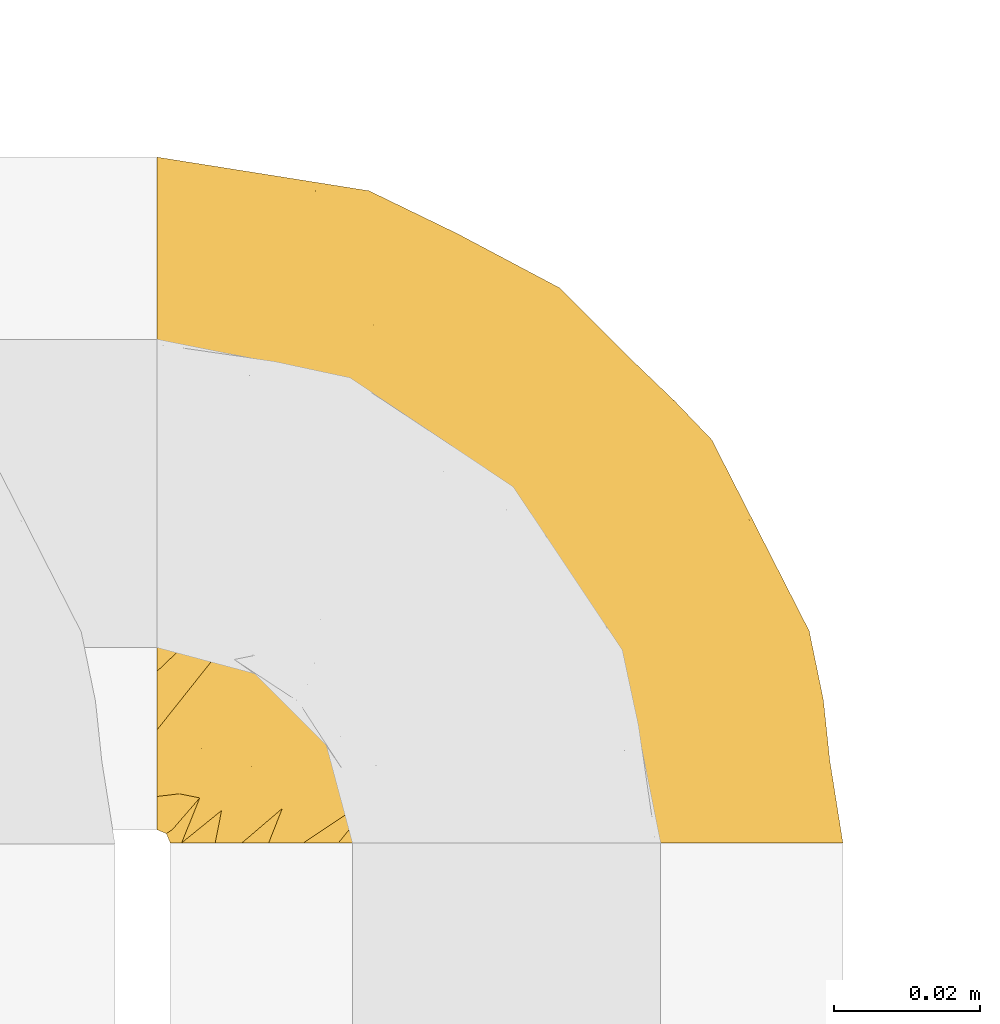
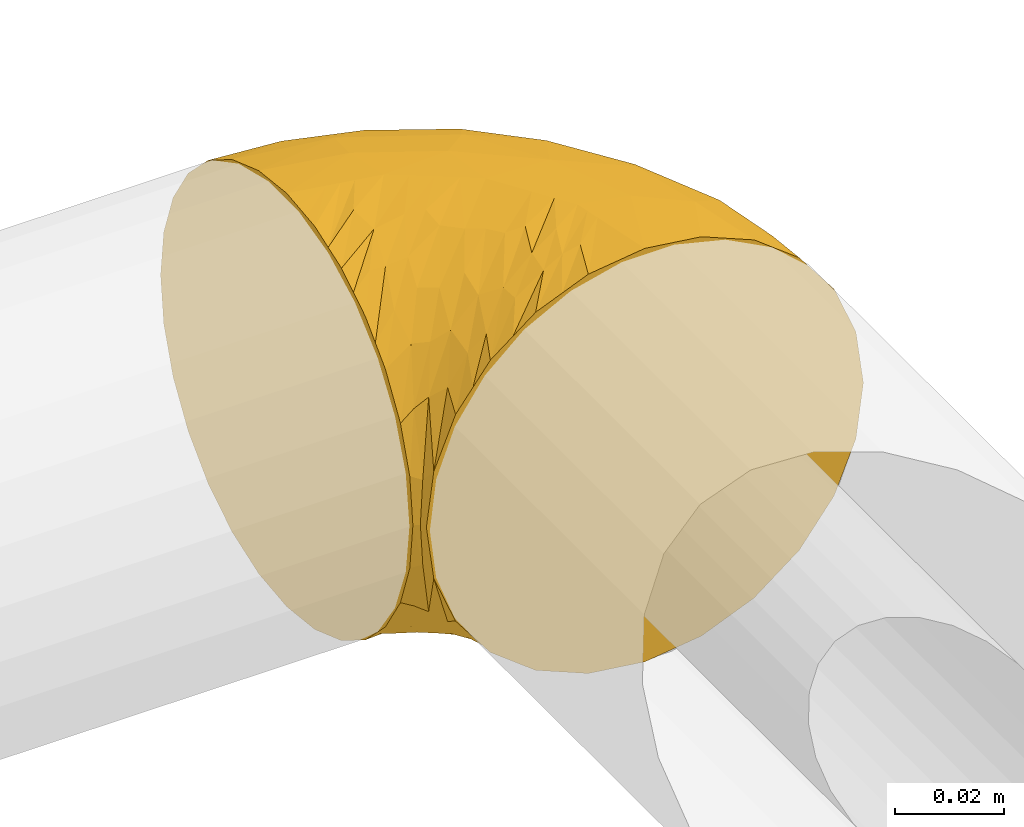
# One storey, part 514 of 827: 1 covering.
"""IFC2X3 building model written with IfcOpenShell, lengths in millimetres."""

from ifc_helpers import new_model, entity, si_unit, converted_unit, derived_unit, direction, frame, origin, place, context, subcontext, project, spatial, faceted_brep, element, save


model = new_model("IFC2X3")

# Units and contexts
model_context = context("Model", 3, precision=0.01, world=origin(), true_north=direction((6.12303176911189e-17, 1.0)))
body_context = subcontext(model_context, "Body", "Model", "MODEL_VIEW")
ifc_project = project(units=[si_unit("LENGTHUNIT", "METRE", prefix="MILLI"), si_unit("AREAUNIT", "SQUARE_METRE"), si_unit("VOLUMEUNIT", "CUBIC_METRE"), converted_unit("PLANEANGLEUNIT", "DEGREE", entity("IfcRatioMeasure", 0.0174532925199433), si_unit("PLANEANGLEUNIT", "RADIAN"), dimensions=[0, 0, 0, 0, 0, 0, 0]), si_unit("MASSUNIT", "GRAM", prefix="KILO"), derived_unit("MASSDENSITYUNIT", [(si_unit("MASSUNIT", "GRAM", prefix="KILO"), 1), (si_unit("LENGTHUNIT", "METRE"), -3)]), derived_unit("MOMENTOFINERTIAUNIT", [(si_unit("LENGTHUNIT", "METRE"), 4)]), si_unit("TIMEUNIT", "SECOND"), si_unit("FREQUENCYUNIT", "HERTZ"), si_unit("THERMODYNAMICTEMPERATUREUNIT", "DEGREE_CELSIUS"), derived_unit("THERMALTRANSMITTANCEUNIT", [(si_unit("MASSUNIT", "GRAM", prefix="KILO"), 1), (si_unit("THERMODYNAMICTEMPERATUREUNIT", "KELVIN"), -1), (si_unit("TIMEUNIT", "SECOND"), -3)]), derived_unit("VOLUMETRICFLOWRATEUNIT", [(si_unit("LENGTHUNIT", "METRE"), 3), (si_unit("TIMEUNIT", "SECOND"), -1)]), derived_unit("MASSFLOWRATEUNIT", [(si_unit("MASSUNIT", "GRAM", prefix="KILO"), 1), (si_unit("TIMEUNIT", "SECOND"), -1)]), derived_unit("ROTATIONALFREQUENCYUNIT", [(si_unit("TIMEUNIT", "SECOND"), -1)]), si_unit("ELECTRICCURRENTUNIT", "AMPERE"), si_unit("ELECTRICVOLTAGEUNIT", "VOLT"), si_unit("POWERUNIT", "WATT"), si_unit("FORCEUNIT", "NEWTON", prefix="KILO"), si_unit("ILLUMINANCEUNIT", "LUX"), si_unit("LUMINOUSFLUXUNIT", "LUMEN"), si_unit("LUMINOUSINTENSITYUNIT", "CANDELA"), derived_unit("USERDEFINED", [(si_unit("MASSUNIT", "GRAM", prefix="KILO"), -1), (si_unit("LENGTHUNIT", "METRE"), -2), (si_unit("TIMEUNIT", "SECOND"), 3), (si_unit("LUMINOUSFLUXUNIT", "LUMEN"), 1)]), derived_unit("LINEARVELOCITYUNIT", [(si_unit("LENGTHUNIT", "METRE"), 1), (si_unit("TIMEUNIT", "SECOND"), -1)]), si_unit("PRESSUREUNIT", "PASCAL"), derived_unit("USERDEFINED", [(si_unit("LENGTHUNIT", "METRE"), -2), (si_unit("MASSUNIT", "GRAM", prefix="KILO"), 1), (si_unit("TIMEUNIT", "SECOND"), -2)]), derived_unit("LINEARFORCEUNIT", [(si_unit("MASSUNIT", "GRAM", prefix="KILO"), 1), (si_unit("LENGTHUNIT", "METRE"), 1), (si_unit("TIMEUNIT", "SECOND"), -2), (si_unit("LENGTHUNIT", "METRE"), -1)]), derived_unit("PLANARFORCEUNIT", [(si_unit("MASSUNIT", "GRAM", prefix="KILO"), 1), (si_unit("LENGTHUNIT", "METRE"), 1), (si_unit("TIMEUNIT", "SECOND"), -2), (si_unit("LENGTHUNIT", "METRE"), -2)])], contexts=[model_context])

# Site, building, storey
site_placement = place(None, origin())
site = spatial("IfcSite", under=ifc_project, at=site_placement, CompositionType="ELEMENT")
building_placement = place(site_placement, origin())
building = spatial("IfcBuilding", under=site, at=building_placement, CompositionType="ELEMENT")
storey_placement = place(building_placement, frame((0.0, 0.0, 28200.0)))
storey = spatial("IfcBuildingStorey", under=building, at=storey_placement, Name="08", CompositionType="ELEMENT", Elevation=28200.0)

# Covering
covering_placement = place(storey_placement, frame((61103.04, 18766.5, 2286.95)))
element("IfcCovering", 1, at=covering_placement, inside=storey, Name=":ADSK_", ObjectType=":ADSK_", PredefinedType="INSULATION", context=body_context, shape_type="Brep", body=[
    faceted_brep([(1.6, 78.41, 83.91), (1.6, 85.72, 76.59), (1.6, 91.22, 67.83), (1.6, 94.64, 58.07), (1.6, 95.8, 47.8), (1.6, 94.64, 37.51), (1.6, 91.22, 27.74), (1.6, 85.71, 18.98), (1.6, 78.39, 11.67), (1.6, 69.63, 6.17), (1.6, 59.87, 2.75), (1.6, 49.6, 1.6), (1.6, 45.45, 2.06), (1.6, 42.38, 2.41), (1.6, 39.31, 2.75), (1.6, 34.43, 4.46), (1.6, 29.54, 6.17), (1.6, 25.16, 8.93), (1.6, 20.78, 11.68), (1.6, 17.13, 15.34), (1.6, 13.47, 19.0), (1.6, 7.97, 27.76), (1.6, 6.26, 32.64), (1.6, 4.55, 37.52), (1.6, 3.4, 47.8), (1.6, 4.55, 58.08), (1.6, 6.26, 62.96), (1.6, 7.97, 67.85), (1.6, 13.48, 76.61), (1.6, 17.14, 80.26), (1.6, 20.8, 83.92), (1.6, 25.18, 86.67), (1.6, 29.56, 89.42), (1.6, 34.44, 91.13), (1.6, 39.32, 92.84), (1.6, 42.39, 93.18), (1.6, 45.45, 93.53), (1.6, 49.6, 94.0), (1.6, 59.88, 92.84), (1.6, 69.65, 89.42), (3.4, 1.6, 47.8), (4.97, 1.6, 35.84), (9.58, 1.6, 24.7), (13.26, 1.6, 19.91), (16.93, 1.6, 15.13), (21.71, 1.6, 11.46), (26.5, 1.6, 7.78), (32.07, 1.6, 5.48), (37.64, 1.6, 3.17), (41.25, 1.6, 2.69), (43.34, 1.6, 2.42), (45.42, 1.6, 2.14), (49.6, 1.6, 1.6), (61.55, 1.6, 3.17), (72.7, 1.6, 7.78), (82.26, 1.6, 15.13), (89.61, 1.6, 24.7), (94.22, 1.6, 35.84), (95.8, 1.6, 47.8), (94.22, 1.6, 59.75), (89.61, 1.6, 70.9), (82.26, 1.6, 80.46), (72.7, 1.6, 87.81), (61.55, 1.6, 92.42), (49.6, 1.6, 94.0), (45.42, 1.6, 93.45), (41.25, 1.6, 92.9), (37.64, 1.6, 92.42), (32.07, 1.6, 90.11), (26.5, 1.6, 87.81), (21.71, 1.6, 84.13), (16.93, 1.6, 80.46), (13.26, 1.6, 75.68), (9.58, 1.6, 70.9), (4.97, 1.6, 59.75), (81.55, 36.81, 71.98), (90.4, 23.28, 63.6), (83.0, 45.8, 59.72), (91.18, 30.7, 47.8), (93.13, 21.2, 55.16), (94.0, 12.96, 47.8), (66.19, 66.19, 63.76), (70.92, 54.51, 72.22), (85.95, 17.98, 74.18), (49.74, 36.69, 92.52), (35.54, 35.54, 94.0), (38.14, 31.64, 94.0), (40.74, 27.75, 94.0), (43.34, 23.86, 94.0), (45.94, 19.96, 94.0), (77.59, 22.8, 82.14), (71.17, 42.67, 80.34), (65.81, 33.21, 87.52), (59.03, 59.45, 79.59), (45.85, 71.5, 78.25), (45.79, 62.66, 85.01), (41.42, 54.5, 90.25), (34.51, 47.57, 93.2), (56.04, 48.81, 87.23), (15.15, 74.98, 85.55), (56.51, 18.7, 93.0), (68.39, 15.75, 89.31), (23.33, 91.17, 61.31), (42.86, 85.28, 56.86), (39.42, 82.58, 68.34), (53.58, 75.78, 65.71), (59.17, 74.98, 56.99), (59.06, 67.27, 72.15), (22.63, 87.38, 70.34), (20.55, 82.04, 78.36), (12.96, 94.0, 47.8), (56.96, 77.8, 47.8), (67.38, 67.38, 47.8), (18.72, 56.2, 93.06), (5.33, 48.85, 94.0), (9.07, 48.11, 94.0), (11.79, 47.57, 94.0), (14.51, 47.03, 94.0), (17.24, 46.48, 94.0), (19.96, 45.94, 94.0), (21.03, 65.78, 89.88), (46.48, 17.24, 94.0), (47.03, 14.51, 94.0), (47.57, 11.79, 94.0), (48.11, 9.07, 94.0), (48.48, 7.2, 94.0), (48.85, 5.33, 94.0), (30.7, 91.18, 47.8), (23.86, 43.34, 94.0), (27.75, 40.74, 94.0), (31.64, 38.14, 94.0), (31.26, 72.73, 83.7), (77.8, 56.96, 47.8), (72.75, 62.23, 55.9), (43.83, 84.49, 47.8), (84.49, 43.83, 47.8), (14.58, 12.05, 81.75), (16.17, 18.95, 86.43), (10.82, 13.02, 79.8), (4.64, 8.34, 69.84), (7.71, 14.63, 79.5), (25.13, 11.09, 88.08), (32.66, 13.66, 91.6), (34.94, 20.08, 92.93), (36.76, 9.61, 92.43), (40.48, 9.48, 93.24), (39.25, 16.1, 93.36), (3.69, 3.42, 57.25), (13.99, 26.63, 89.41), (21.85, 33.72, 92.89), (17.93, 34.77, 92.66), (15.11, 6.75, 79.58), (21.14, 13.31, 86.51), (12.7, 21.11, 86.29), (7.21, 19.94, 83.91), (10.45, 6.04, 73.94), (32.27, 8.67, 90.94), (25.68, 26.11, 91.94), (22.18, 29.3, 91.98), (18.79, 6.32, 82.79), (10.12, 39.92, 93.16), (9.47, 27.05, 88.76), (11.29, 34.4, 91.89), (2.87, 2.87, 47.8), (31.16, 20.92, 92.22), (6.31, 27.43, 88.56), (25.62, 7.54, 87.72), (21.18, 18.45, 88.33), (28.81, 23.88, 92.18), (7.45, 7.77, 71.78), (21.17, 18.43, 7.27), (16.17, 18.93, 9.17), (25.69, 26.08, 3.66), (48.11, 9.07, 1.6), (48.85, 5.33, 1.6), (47.03, 14.51, 1.6), (47.57, 11.79, 1.6), (3.69, 3.42, 38.35), (7.44, 7.76, 23.84), (14.51, 47.03, 1.6), (11.79, 47.57, 1.6), (5.33, 48.85, 1.6), (9.07, 48.11, 1.6), (7.71, 14.62, 16.1), (9.47, 27.03, 6.84), (34.94, 20.08, 2.66), (31.16, 20.92, 3.37), (40.74, 27.75, 1.6), (38.14, 31.64, 1.6), (18.79, 6.33, 12.8), (36.76, 9.61, 3.16), (40.48, 9.48, 2.35), (4.63, 8.33, 25.77), (21.14, 13.3, 9.09), (15.11, 6.74, 16.02), (14.58, 12.04, 13.85), (43.34, 23.86, 1.6), (45.94, 19.96, 1.6), (39.25, 16.1, 2.23), (7.21, 19.93, 11.69), (12.69, 21.1, 9.31), (10.14, 39.92, 2.43), (21.81, 33.68, 2.71), (22.19, 29.28, 3.61), (14.0, 26.62, 6.18), (6.66, 27.87, 6.77), (17.92, 34.75, 2.93), (10.45, 6.04, 21.66), (31.64, 38.14, 1.6), (10.64, 12.79, 16.09), (11.31, 34.41, 3.7), (19.96, 45.94, 1.6), (23.86, 43.34, 1.6), (27.75, 40.74, 1.6), (32.66, 13.66, 3.99), (46.48, 17.24, 1.6), (32.27, 8.67, 4.65), (25.13, 11.09, 7.51), (35.54, 35.54, 1.6), (28.77, 23.83, 3.43), (23.36, 6.03, 9.46), (17.24, 46.48, 1.6), (47.58, 34.52, 2.4), (93.13, 21.2, 40.43), (77.44, 23.82, 13.57), (66.78, 41.32, 11.3), (71.68, 47.62, 18.65), (74.96, 52.66, 27.26), (81.55, 36.81, 23.61), (36.7, 49.75, 3.07), (56.9, 19.07, 2.69), (83.0, 45.8, 35.87), (90.4, 23.28, 31.99), (67.83, 21.35, 6.71), (85.95, 17.98, 21.41), (39.41, 82.57, 27.24), (23.33, 91.17, 34.26), (42.87, 85.27, 38.73), (53.92, 73.89, 26.97), (66.19, 66.19, 31.83), (64.12, 62.43, 23.4), (33.13, 63.53, 6.91), (23.1, 58.45, 3.4), (16.98, 67.16, 5.84), (72.75, 62.22, 39.69), (23.77, 81.54, 17.6), (18.41, 74.8, 10.38), (43.7, 75.83, 20.6), (54.53, 41.45, 5.36), (55.72, 76.72, 35.73), (17.73, 88.2, 24.84), (38.98, 71.6, 13.87), (50.28, 56.23, 9.06), (59.02, 59.44, 15.99)], [[[0, 1, 2, 3, 4, 5, 6, 7, 8, 9, 10, 11, 12, 13, 14, 15, 16, 17, 18, 19, 20, 21, 22, 23, 24, 25, 26, 27, 28, 29, 30, 31, 32, 33, 34, 35, 36, 37, 38, 39]], [[40, 41, 42, 43, 44, 45, 46, 47, 48, 49, 50, 51, 52, 53, 54, 55, 56, 57, 58, 59, 60, 61, 62, 63, 64, 65, 66, 67, 68, 69, 70, 71, 72, 73, 74]], [[75, 76, 77]], [[78, 79, 80]], [[77, 81, 82]], [[76, 75, 83]], [[84, 85, 86, 87, 88, 89]], [[90, 91, 92]], [[76, 60, 59]], [[93, 94, 95]], [[90, 62, 61]], [[83, 61, 60]], [[96, 97, 84]], [[98, 93, 95]], [[0, 39, 99]], [[100, 84, 89]], [[62, 101, 63]], [[2, 102, 3]], [[92, 84, 100]], [[103, 102, 104]], [[103, 105, 106]], [[93, 107, 94]], [[1, 108, 2]], [[92, 101, 90]], [[108, 1, 109]], [[102, 110, 3]], [[93, 82, 107]], [[102, 108, 104]], [[111, 106, 112]], [[109, 0, 99]], [[113, 37, 114, 115, 116, 117, 118, 119]], [[120, 38, 113]], [[100, 89, 121, 122, 123, 124, 125, 126, 64]], [[127, 102, 103]], [[97, 119, 128, 129, 130, 85]], [[99, 120, 131]], [[132, 133, 77]], [[59, 80, 79]], [[1, 0, 109]], [[98, 84, 92]], [[94, 109, 131]], [[120, 39, 38]], [[93, 91, 82]], [[104, 94, 105]], [[97, 113, 119]], [[95, 120, 96]], [[83, 90, 61]], [[91, 93, 98]], [[64, 63, 100]], [[100, 63, 101]], [[77, 76, 79]], [[133, 106, 81]], [[84, 97, 85]], [[113, 96, 120]], [[113, 97, 96]], [[37, 113, 38]], [[110, 102, 127]], [[110, 4, 3]], [[103, 111, 134, 127]], [[90, 75, 91]], [[82, 81, 107]], [[91, 75, 82]], [[77, 82, 75]], [[76, 83, 60]], [[90, 83, 75]], [[105, 107, 81]], [[94, 131, 95]], [[105, 94, 107]], [[109, 94, 104]], [[120, 95, 131]], [[98, 95, 96]], [[84, 98, 96]], [[98, 92, 91]], [[106, 105, 81]], [[103, 104, 105]], [[112, 106, 133]], [[103, 106, 111]], [[112, 133, 132]], [[81, 77, 133]], [[77, 78, 135, 132]], [[120, 99, 39]], [[109, 99, 131]], [[59, 58, 80]], [[59, 79, 76]], [[90, 101, 62]], [[100, 101, 92]], [[2, 108, 102]], [[109, 104, 108]], [[78, 77, 79]], [[136, 137, 138]], [[27, 139, 140]], [[141, 142, 143]], [[144, 145, 121]], [[146, 89, 88]], [[147, 139, 25]], [[148, 149, 150]], [[136, 151, 152]], [[147, 40, 74]], [[24, 147, 25]], [[140, 153, 154]], [[33, 116, 34]], [[73, 151, 155]], [[114, 37, 36, 35, 34, 116, 115]], [[146, 156, 144]], [[157, 85, 130]], [[158, 149, 148]], [[151, 159, 152]], [[117, 33, 160]], [[29, 154, 161]], [[155, 74, 73]], [[162, 128, 119]], [[65, 64, 126, 125, 124, 123, 122, 67, 66]], [[163, 147, 24]], [[27, 140, 28]], [[149, 129, 150]], [[139, 27, 26, 25]], [[68, 144, 69]], [[129, 128, 150]], [[164, 87, 86]], [[130, 129, 149]], [[122, 145, 67]], [[154, 153, 148]], [[162, 119, 160]], [[165, 30, 161]], [[150, 161, 148]], [[128, 162, 150]], [[30, 165, 31]], [[145, 144, 68]], [[89, 146, 144]], [[87, 164, 143]], [[166, 156, 142]], [[88, 87, 143]], [[162, 161, 150]], [[161, 30, 29]], [[154, 29, 28]], [[140, 154, 28]], [[161, 154, 148]], [[140, 137, 153]], [[158, 148, 153]], [[157, 130, 158]], [[153, 137, 158]], [[158, 137, 157]], [[167, 137, 136]], [[168, 85, 157]], [[152, 168, 167]], [[167, 168, 157]], [[164, 152, 141]], [[151, 73, 72]], [[159, 72, 71]], [[88, 142, 146]], [[144, 156, 69]], [[146, 142, 156]], [[70, 166, 71]], [[142, 141, 166]], [[70, 69, 156]], [[141, 159, 71]], [[167, 136, 152]], [[138, 137, 140]], [[155, 136, 169]], [[136, 155, 151]], [[74, 155, 169]], [[152, 159, 141]], [[151, 72, 159]], [[168, 152, 164]], [[137, 167, 157]], [[164, 86, 168]], [[85, 168, 86]], [[116, 33, 117]], [[130, 149, 158]], [[67, 145, 68]], [[121, 89, 144]], [[145, 122, 121]], [[40, 147, 163]], [[169, 147, 74]], [[160, 33, 32]], [[162, 160, 32]], [[160, 119, 118, 117]], [[139, 147, 169]], [[139, 169, 138]], [[162, 32, 31]], [[141, 143, 164]], [[88, 143, 142]], [[71, 166, 141]], [[156, 166, 70]], [[139, 138, 140]], [[169, 136, 138]], [[161, 162, 165]], [[162, 31, 165]], [[170, 171, 172]], [[173, 174, 52, 51, 50, 49, 48, 175, 176]], [[177, 178, 41]], [[179, 15, 180]], [[12, 11, 181, 182, 180, 14, 13]], [[183, 21, 20]], [[19, 18, 184]], [[185, 186, 187]], [[186, 188, 187]], [[43, 189, 44]], [[190, 191, 47]], [[23, 22, 21, 192]], [[193, 194, 195]], [[40, 163, 177]], [[196, 197, 198]], [[24, 23, 177]], [[199, 200, 183]], [[201, 15, 179]], [[178, 177, 192]], [[47, 46, 190]], [[202, 203, 204]], [[203, 172, 171]], [[205, 206, 184]], [[207, 41, 178]], [[16, 15, 201]], [[14, 180, 15]], [[204, 203, 200]], [[208, 203, 202]], [[163, 24, 177]], [[48, 47, 191]], [[198, 197, 190]], [[199, 184, 204]], [[171, 195, 209]], [[210, 211, 212]], [[206, 212, 213]], [[205, 17, 210]], [[184, 206, 204]], [[210, 212, 206]], [[185, 196, 214]], [[190, 215, 191]], [[216, 45, 214]], [[186, 217, 193]], [[190, 216, 198]], [[199, 20, 19]], [[196, 185, 187]], [[199, 183, 20]], [[184, 199, 19]], [[199, 204, 200]], [[206, 202, 204]], [[171, 183, 200]], [[203, 208, 172]], [[172, 208, 218]], [[171, 200, 203]], [[218, 188, 219]], [[195, 170, 193]], [[217, 186, 185]], [[193, 219, 186]], [[193, 170, 219]], [[207, 194, 42]], [[217, 220, 189]], [[216, 190, 46]], [[214, 196, 198]], [[44, 220, 45]], [[214, 198, 216]], [[216, 46, 45]], [[214, 45, 220]], [[42, 194, 43]], [[189, 193, 217]], [[207, 195, 194]], [[209, 195, 178]], [[41, 207, 42]], [[195, 207, 178]], [[43, 194, 189]], [[193, 189, 194]], [[171, 170, 195]], [[170, 172, 219]], [[218, 219, 172]], [[188, 186, 219]], [[206, 213, 202]], [[208, 202, 213]], [[201, 210, 16]], [[215, 190, 197]], [[215, 175, 191]], [[175, 48, 191]], [[201, 179, 221, 211]], [[210, 201, 211]], [[23, 192, 177]], [[40, 177, 41]], [[192, 183, 209]], [[21, 183, 192]], [[205, 18, 17]], [[17, 16, 210]], [[217, 185, 214]], [[189, 220, 44]], [[214, 220, 217]], [[192, 209, 178]], [[171, 209, 183]], [[206, 205, 210]], [[18, 205, 184]], [[222, 197, 196, 187, 188, 218]], [[57, 223, 80]], [[224, 225, 226]], [[226, 227, 228]], [[229, 218, 208, 213, 212, 211]], [[230, 52, 174, 173, 176, 175, 215, 197]], [[231, 232, 228]], [[231, 78, 223]], [[223, 57, 232]], [[224, 233, 225]], [[233, 54, 53]], [[234, 232, 56]], [[56, 55, 234]], [[234, 224, 228]], [[235, 236, 237]], [[224, 55, 54]], [[238, 239, 240]], [[52, 230, 53]], [[241, 242, 243]], [[231, 227, 244]], [[11, 10, 242]], [[236, 6, 5]], [[7, 245, 8]], [[8, 246, 9]], [[238, 247, 235]], [[222, 229, 248]], [[242, 211, 221, 179, 180, 182, 181, 11]], [[233, 53, 230]], [[111, 112, 249]], [[250, 6, 236]], [[246, 251, 241]], [[6, 250, 7]], [[127, 236, 110]], [[248, 229, 252]], [[246, 8, 245]], [[235, 245, 250]], [[236, 5, 110]], [[235, 249, 238]], [[237, 236, 127]], [[243, 9, 246]], [[252, 229, 241]], [[56, 232, 57]], [[222, 230, 197]], [[225, 248, 252]], [[248, 233, 230]], [[54, 233, 224]], [[231, 228, 227]], [[244, 132, 231]], [[248, 225, 233]], [[226, 225, 253]], [[235, 250, 236]], [[245, 7, 250]], [[251, 246, 245]], [[243, 246, 241]], [[247, 245, 235]], [[252, 251, 253]], [[229, 222, 218]], [[230, 222, 248]], [[5, 4, 110]], [[237, 127, 134, 111]], [[238, 249, 239]], [[224, 234, 55]], [[232, 234, 228]], [[242, 241, 229]], [[10, 9, 243]], [[211, 242, 229]], [[10, 243, 242]], [[80, 223, 78]], [[80, 58, 57]], [[231, 223, 232]], [[227, 240, 239]], [[224, 226, 228]], [[240, 226, 253]], [[227, 239, 244]], [[226, 240, 227]], [[251, 247, 253]], [[240, 253, 247]], [[249, 235, 237]], [[237, 111, 249]], [[244, 239, 249]], [[112, 244, 249]], [[135, 78, 231, 132]], [[112, 132, 244]], [[247, 238, 240]], [[245, 247, 251]], [[251, 252, 241]], [[225, 252, 253]]]),
])

save(model, "model.ifc")
